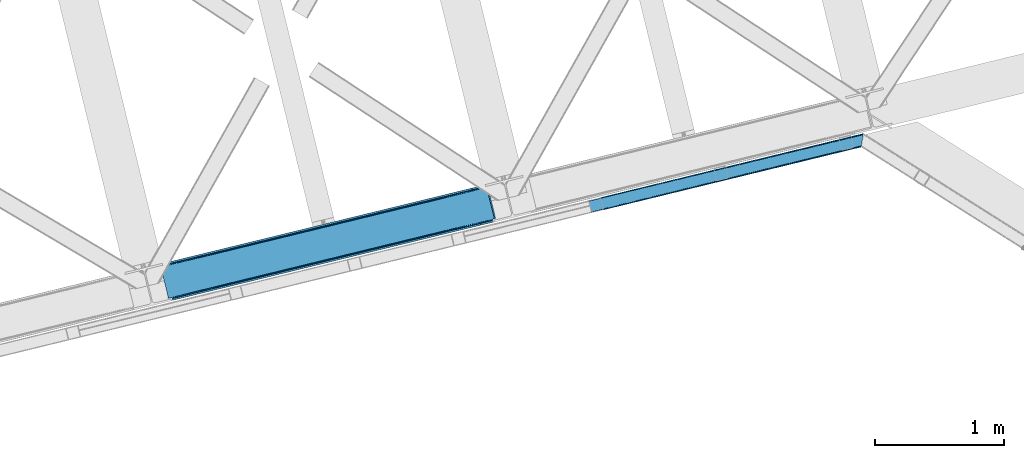
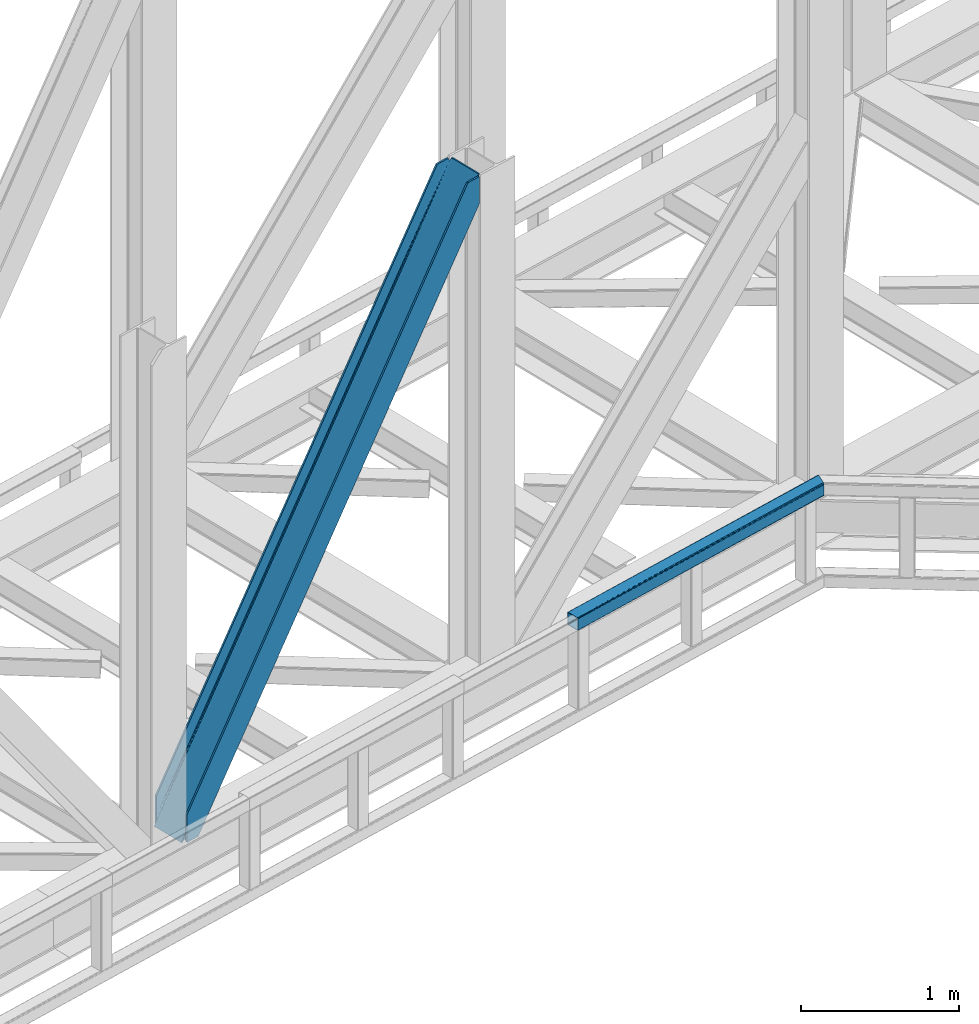
# One storey, part 71 of 92: 1 beam, 1 member.
"""IFC4 building model written with IfcOpenShell, lengths in millimetres."""

from ifc_helpers import new_model, entity, si_unit, converted_unit, derived_unit, direction, frame, origin, place, context, subcontext, project, spatial, triangles, type_object, element, save


model = new_model("IFC4")

# Units and contexts
model_context = context("Model", 3, precision=0.01, world=origin(), true_north=direction((6.12303176911189e-17, 1.0)))
plan_context = context("Plan", 3, precision=0.01, world=origin(), true_north=direction((6.12303176911189e-17, 1.0)))
body_context = subcontext(model_context, "Body", "Model", "MODEL_VIEW")
ifc_project = project(units=[si_unit("LENGTHUNIT", "METRE", prefix="MILLI"), si_unit("AREAUNIT", "SQUARE_METRE"), si_unit("VOLUMEUNIT", "CUBIC_METRE"), converted_unit("PLANEANGLEUNIT", "DEGREE", entity("IfcRatioMeasure", 0.0174532925199433), si_unit("PLANEANGLEUNIT", "RADIAN"), dimensions=[0, 0, 0, 0, 0, 0, 0]), si_unit("MASSUNIT", "GRAM", prefix="KILO"), derived_unit("MASSDENSITYUNIT", [(si_unit("MASSUNIT", "GRAM", prefix="KILO"), 1), (si_unit("LENGTHUNIT", "METRE"), -3)]), derived_unit("MOMENTOFINERTIAUNIT", [(si_unit("LENGTHUNIT", "METRE"), 4)]), si_unit("TIMEUNIT", "SECOND"), si_unit("FREQUENCYUNIT", "HERTZ"), si_unit("THERMODYNAMICTEMPERATUREUNIT", "DEGREE_CELSIUS"), derived_unit("THERMALTRANSMITTANCEUNIT", [(si_unit("MASSUNIT", "GRAM", prefix="KILO"), 1), (si_unit("THERMODYNAMICTEMPERATUREUNIT", "KELVIN"), -1), (si_unit("TIMEUNIT", "SECOND"), -3)]), derived_unit("VOLUMETRICFLOWRATEUNIT", [(si_unit("LENGTHUNIT", "METRE"), 3), (si_unit("TIMEUNIT", "SECOND"), -1)]), derived_unit("MASSFLOWRATEUNIT", [(si_unit("MASSUNIT", "GRAM", prefix="KILO"), 1), (si_unit("TIMEUNIT", "SECOND"), -1)]), derived_unit("ROTATIONALFREQUENCYUNIT", [(si_unit("TIMEUNIT", "SECOND"), -1)]), si_unit("ELECTRICCURRENTUNIT", "AMPERE"), si_unit("ELECTRICVOLTAGEUNIT", "VOLT"), si_unit("POWERUNIT", "WATT"), si_unit("FORCEUNIT", "NEWTON", prefix="KILO"), si_unit("ILLUMINANCEUNIT", "LUX"), si_unit("LUMINOUSFLUXUNIT", "LUMEN"), si_unit("LUMINOUSINTENSITYUNIT", "CANDELA"), derived_unit("USERDEFINED", [(si_unit("MASSUNIT", "GRAM", prefix="KILO"), -1), (si_unit("LENGTHUNIT", "METRE"), -2), (si_unit("TIMEUNIT", "SECOND"), 3), (si_unit("LUMINOUSFLUXUNIT", "LUMEN"), 1)]), derived_unit("LINEARVELOCITYUNIT", [(si_unit("LENGTHUNIT", "METRE"), 1), (si_unit("TIMEUNIT", "SECOND"), -1)]), si_unit("PRESSUREUNIT", "PASCAL"), derived_unit("USERDEFINED", [(si_unit("LENGTHUNIT", "METRE"), -2), (si_unit("MASSUNIT", "GRAM", prefix="KILO"), 1), (si_unit("TIMEUNIT", "SECOND"), -2)]), derived_unit("LINEARFORCEUNIT", [(si_unit("MASSUNIT", "GRAM", prefix="KILO"), 1), (si_unit("LENGTHUNIT", "METRE"), 1), (si_unit("TIMEUNIT", "SECOND"), -2), (si_unit("LENGTHUNIT", "METRE"), -1)]), derived_unit("PLANARFORCEUNIT", [(si_unit("MASSUNIT", "GRAM", prefix="KILO"), 1), (si_unit("LENGTHUNIT", "METRE"), 1), (si_unit("TIMEUNIT", "SECOND"), -2), (si_unit("LENGTHUNIT", "METRE"), -2)])], contexts=[model_context, plan_context])

# Site, building, storey
site_placement = place(None, origin())
site = spatial("IfcSite", under=ifc_project, at=site_placement, CompositionType="ELEMENT")
building_placement = place(site_placement, origin())
building = spatial("IfcBuilding", under=site, at=building_placement, CompositionType="ELEMENT")
storey_placement = place(building_placement, frame((0.0, 0.0, 15900.0)))
storey = spatial("IfcBuildingStorey", under=building, at=storey_placement, Name="05", CompositionType="ELEMENT", Elevation=15900.0)

# Member
member_type = type_object("IfcMemberType", PredefinedType="BRACE")
member_placement = place(storey_placement, frame((-10911.6, 14812.79, 3695.0)))
element("IfcMember", 1, at=member_placement, inside=storey, type_object=member_type, ObjectType="Steel Vertical Brace", PredefinedType="BRACE", context=body_context, shape_type="Tessellation", body=[
    triangles([(2543.71740875244, 876.026760864259, 3910.2403930664), (2543.86042327881, 877.205758666993, 3909.96134033203), (2542.34249267578, 876.83485107422, 3911.00081176758), (2544.23714447021, 869.063232421875, 3911.00081176758), (2527.1870223999, 873.140890502929, 3906.29412231445), (2530.23276672363, 873.883868408204, 3911.00081176758), (2527.1870223999, 873.140890502929, 3884.1908203125), (2518.86892547607, 874.429183959961, 3898.31321411133), (2521.01472473145, 873.423431396484, 3899.16199951172), (2522.8994934082, 872.957180786134, 3877.06799926758), (2518.86892547607, 874.429183959961, 3868.81036376953), (2517.28762664795, 875.594229125976, 3898.850390625), (2517.28762664795, 875.594229125976, 3864.49202270508), (2515.87201538086, 877.455743408203, 3857.29478759765), (2515.70574645996, 877.331332397462, 3901.61533813476), (2513.8953918457, 881.222955322266, 3911.00081176758), (2514.70987701416, 878.98239440918, 3851.39514770508), (2514.17793273926, 880.262548828125, 3838.64708862305), (2514.70987701416, 878.98239440918, 3906.82664794922), (2514.37326965332, 879.734674072266, 3911.00081176758), (2514.17793273926, 880.262548828125, 3698.36960449219), (2513.8953918457, 881.222955322266, 3698.30216674805), (2522.8994934082, 872.957180786134, 3900.77120361328), (1281.82757263184, 579.864605712892, 1933.79126586914), (121.508862304687, 297.023730468751, 0.0), (1706.0627243042, 683.275735473633, 2589.5349609375), (2130.29787597656, 786.688027954102, 3245.28098144531), (857.588351440429, 476.451150512696, 1278.04757080078), (30.7527740478508, 274.901824951172, 0.0), (433.352618408202, 373.040020751954, 622.301550292967), (2511.05370483398, 892.881546020508, 3698.30216674805), (118.429980468749, 309.6543548584, 0.0), (2511.05370483398, 892.881546020508, 3911.00081176758), (2415.21013641357, 869.519018554687, 3911.00081176758), (23.8834259033192, 286.608087158203, 214.700848388671), (23.8834259033192, 286.608087158203, 0.0), (26.9576568603516, 273.658877563477, 0.0), (26.7251129150391, 274.949496459962, 0.0), (26.7251129150391, 274.949496459962, 214.700848388671), (2509.04452514648, 879.011462402344, 3911.00081176758), (2418.28901824951, 856.88839416504, 3911.00081176758), (26.9169616699219, 273.966998291016, 214.633410644528), (1250.04869842529, 572.117404174805, 1964.95680541992), (1676.92729339599, 676.173843383789, 2624.78862304687), (2103.80530700683, 780.230282592775, 3284.61811523437), (823.166033935546, 468.06096496582, 1305.12731323242), (26.9169616699219, 273.966998291016, 74.3536010742173), (396.287438964842, 364.004525756836, 645.295495605467), (25.4356567382802, 266.62907409668, 14.6874755859353), (23.9973724365227, 264.751281738281, 13.8410156249993), (22.5346710205067, 263.467639160157, 35.9326904296868), (25.4356567382802, 266.62907409668, 44.192651367186), (26.2995574951165, 268.389431762696, 14.1502990722656), (26.0007385253903, 268.182467651368, 48.2249633789033), (26.9088226318345, 270.661386108399, 54.6571289062485), (26.9088226318345, 270.661386108399, 11.3853515624978), (27.0332336425781, 272.584524536132, 61.6055419921868), (27.0332336425781, 272.584524536132, 6.17404174804688), (22.5346710205067, 263.467639160157, 12.2294860839829), (18.6395599365223, 261.656121826172, 28.8121948242188), (18.6395599365223, 261.656121826172, 6.70889282226563), (0.0, 257.112213134766, 0.0), (14.3014526367188, 260.598046875, 0.0), (412.365527343749, 356.486380004882, 636.079779052732), (0.597637939452397, 256.057626342774, 0.0), (4.0857971191399, 249.874282836914, 0.0), (2122.62276306152, 766.290435791016, 3274.64197998047), (2534.31856384277, 866.644775390625, 3911.00081176758), (2530.82982330322, 872.828118896485, 3911.00081176758), (2119.88455810547, 772.712136840821, 3275.40239868164), (2109.70145874023, 780.257025146484, 3280.80206909179), (2115.34762573242, 777.617651367187, 3277.56505737305), (407.828594970702, 361.391894531251, 638.242437744138), (402.183590698241, 364.031268310548, 641.479449462888), (415.109545898436, 350.065841674805, 635.319360351561), (829.062185668945, 468.087707519531, 1301.30894165039), (1255.94019927978, 572.144146728517, 1961.14075927734), (1682.81821289062, 676.199423217773, 2620.97025146484), (834.707189941406, 465.447171020509, 1298.07192993164), (1261.58578491211, 569.503610229493, 1957.90374755859), (1688.46903076172, 673.561212158203, 2617.73323974609), (839.248773193358, 460.543981933593, 1295.90927124023), (1266.12736816406, 564.600421142579, 1955.74108886719), (1693.00596313476, 668.656860351563, 2615.57058105469), (841.986978149413, 454.121118164063, 1295.15117797851), (1268.86557312012, 558.177557373047, 1954.98067016601), (1695.74416809082, 662.233996582032, 2614.81248779297), (428.111077880858, 370.35181274414, 626.119921874997), (424.312472534179, 365.409091186524, 629.35693359375), (2119.48225708008, 772.61446838379, 3254.49669799805), (2121.25307922363, 779.057098388672, 3252.33403930664), (423.061386108398, 352.004095458984, 632.280010986327), (14.0084472656235, 252.292739868164, 0.0), (14.2607574462891, 259.388818359375, 0.0), (422.536999511718, 358.966461181641, 631.519592285156), (2125.05110321045, 783.998657226563, 3249.09702758789), (846.772732543945, 462.377590942384, 1287.26328735351), (847.297119140625, 455.415225219727, 1288.02370605469), (1271.00730285644, 565.789883422853, 1943.00930786133), (1271.53168945312, 558.827517700196, 1943.76740112304), (1695.24245452881, 669.201013183594, 2598.75300292969), (1695.76684112549, 662.239810180665, 2599.5110961914), (2120.00199279785, 765.650939941406, 3255.25711669922), (848.548205566405, 468.821383666993, 1285.10062866211), (1272.78277587891, 572.233676147462, 1940.84664916992), (1697.01792755127, 675.644805908203, 2596.59034423828), (852.345648193359, 473.762942504884, 1281.86361694336), (1276.58079986572, 577.175234985352, 1937.60963745117), (1700.81595153808, 680.586364746094, 2593.35333251953), (2589.49949798584, 640.273709106446, 3911.00081176758), (2177.80311584473, 539.91820678711, 3274.64197998047), (1324.04650726318, 331.806491088868, 1954.98067016601), (1750.92452087402, 435.861767578126, 2614.81248779297), (897.167330932616, 227.750051879882, 1295.15117797851), (470.28989868164, 123.693612670899, 635.319360351561), (59.2661499023434, 23.5020538330082, 0.0), (2599.41749725342, 642.691003417969, 3911.00081176758), (2175.18234558105, 539.279873657228, 3255.25711669922), (1750.94719390869, 435.867581176759, 2599.5110961914), (1326.71204223633, 332.456451416016, 1943.76740112304), (902.477471923827, 229.044158935547, 1288.02370605469), (478.2417388916, 125.631866455078, 632.280010986327), (69.1899627685543, 25.9216735839855, 0.0), (59.0138397216797, 16.4071380615242, 0.0), (72.6781219482418, 19.7383300781257, 0.0), (58.9696563720699, 15.1955841064464, 0.0), (73.2711090087887, 18.6825805664066, 0.0), (77.6092163085923, 19.7394927978512, 6.70889282226563), (77.6092163085923, 19.7394927978512, 28.8121948242188), (2589.24718780517, 633.178793334961, 3911.00081176758), (2601.31214904785, 634.919384765626, 3911.00081176758), (2589.2024230957, 631.967239379883, 3911.00081176758), (2602.83007965088, 635.289129638672, 3909.96134033203), (2602.16035308838, 636.270465087891, 3910.2403930664), (2586.15667877197, 631.22426147461, 3906.29412231445), (2586.15667877197, 631.22426147461, 3884.1908203125), (2572.75052032471, 617.663461303711, 3911.00081176758), (2577.81474609375, 619.473815917969, 3911.00081176758), (2577.76707458496, 620.297021484375, 3906.82664794922), (2172.75865631103, 521.571652221681, 3280.80206909179), (2577.89206695557, 622.220159912109, 3901.61533813476), (2578.49668121338, 624.490951538086, 3898.850390625), (2582.26563720703, 629.413906860353, 3900.77120361328), (2178.32750244141, 532.955841064453, 3275.40239868164), (2580.80293579101, 628.130264282227, 3899.15967407226), (2579.36465148926, 626.252471923828, 3898.31321411133), (2176.55668029785, 526.514373779297, 3277.56505737305), (470.809634399413, 116.730084228517, 636.079779052732), (469.038812255858, 110.28861694336, 638.242437744138), (81.9008148193352, 19.9243652343757, 35.9326904296868), (85.931964111327, 18.4523620605469, 44.192651367186), (87.5086120605465, 17.2861541748043, 48.5109924316384), (2167.51188354492, 518.882281494141, 3284.61811523437), (459.994015502929, 102.656524658203, 645.295495605467), (465.240206909179, 105.345895385743, 641.479449462888), (90.6223754882813, 12.6189971923832, 74.3536010742173), (90.0910125732407, 13.8991516113292, 61.6055419921868), (88.9282928466782, 15.4258026123043, 55.7059020996094), (897.691717529297, 220.787686157228, 1295.90927124023), (1324.57089385986, 324.844125366211, 1955.74108886719), (1751.4489074707, 428.900564575195, 2615.57058105469), (895.916244506836, 214.343893432617, 1298.07192993164), (1322.79483947754, 318.400332641602, 1957.90374755859), (1749.67808532715, 422.457934570313, 2617.73323974609), (892.118801879882, 209.402334594726, 1301.30894165039), (1318.99739685059, 313.458773803712, 1961.14075927734), (1745.87599182129, 417.515213012695, 2620.97025146484), (886.871447753905, 206.712963867189, 1305.12731323242), (1313.75469360351, 310.7705657959, 1964.95680541992), (1740.63328857422, 414.827005004883, 2624.78862304687), (90.6223754882813, 12.6189971923832, 214.633410644528), (2481.99501342773, 595.541555786132, 3911.00081176758), (491.167694091797, 111.666439819337, 626.119921874997), (89.094561767577, 15.550213623048, 11.3853515624978), (87.5086120605465, 17.2861541748043, 14.1502990722656), (90.0910125732407, 13.8991516113292, 6.17404174804688), (480.981106567382, 119.210165405273, 631.519592285156), (83.7855834960938, 19.4581146240234, 13.8386901855447), (81.9008148193352, 19.9243652343757, 12.2294860839829), (85.931964111327, 18.4523620605469, 14.6874755859353), (485.521527099609, 114.305813598634, 629.35693359375), (2182.46213378906, 527.953820800782, 3252.33403930664), (2582.26563720703, 629.413906860353, 3877.06799926758), (2579.36465148926, 626.252471923828, 3868.81036376953), (2177.92520141602, 532.858172607423, 3254.49669799805), (2578.79608154297, 624.697915649414, 3864.77572631836), (2577.89206695557, 622.220159912109, 3858.34588623047), (2188.10830078125, 525.313284301757, 3249.09702758789), (2577.76707458496, 620.297021484375, 3851.39514770508), (94.4593505859375, 13.5538238525387, 0.0), (90.5188934326161, 12.9108398437511, 0.0), (497.059194946289, 111.692019653321, 622.301550292967), (2577.88392791748, 618.915710449219, 3838.64708862305), (2194.00387115478, 525.340026855469, 3245.28098144531), (915.403427124023, 215.077569580078, 1281.86361694336), (921.294927978515, 215.10431213379, 1278.04757080078), (1339.63799743652, 318.489862060547, 1937.60963745117), (1345.53414916992, 318.516604614259, 1933.79126586914), (1763.87314910889, 421.902154541016, 2593.35333251953), (1769.76930084228, 421.928897094727, 2589.5349609375), (909.757260131835, 217.718106079103, 1285.10062866211), (1333.9924118042, 321.129235839844, 1940.84664916992), (1758.2269821167, 424.541528320313, 2596.59034423828), (905.215676879881, 222.621295166016, 1287.26328735351), (1329.45082855225, 326.033587646485, 1943.00930786133), (1753.68598022461, 429.444717407227, 2598.75300292969), (90.9049163818345, 11.6585906982418, 0.0), (90.9049163818345, 11.6585906982418, 214.700848388671), (2485.07389526367, 582.910931396485, 3911.00081176758), (93.7466033935543, 0.0, 214.700848388671), (93.7466033935543, 0.0, 0.0), (188.293157958984, 23.046267700196, 0.0), (185.214276123046, 35.6768920898448, 0.0), (2577.88392791748, 618.915710449219, 3698.36960449219), (2578.07577667236, 617.932049560548, 3911.00081176758), (2578.07577667236, 617.932049560548, 3698.30216674805), (2580.91746368408, 606.273458862304, 3698.30216674805), (2580.91746368408, 606.273458862304, 3911.00081176758)], [[1, 2, 3], [3, 4, 1], [3, 5, 6], [5, 3, 2], [7, 5, 2], [8, 9, 10], [10, 11, 8], [8, 11, 12], [13, 12, 11], [14, 15, 12], [16, 17, 18], [19, 15, 14], [16, 20, 19], [19, 17, 16], [14, 17, 19], [18, 21, 22], [22, 16, 18], [13, 14, 12], [9, 23, 10], [5, 7, 23], [10, 23, 7], [21, 24, 25], [26, 21, 27], [21, 26, 24], [21, 18, 27], [28, 25, 24], [29, 25, 30], [28, 30, 25], [31, 22, 32], [22, 21, 25], [25, 32, 22], [16, 22, 33], [31, 33, 22], [34, 31, 35], [31, 34, 33], [32, 35, 31], [36, 35, 32], [32, 29, 36], [29, 32, 25], [37, 38, 29], [38, 36, 29], [38, 39, 35], [35, 36, 38], [16, 33, 40], [20, 16, 40], [34, 40, 33], [34, 41, 40], [39, 34, 35], [41, 39, 42], [39, 41, 34], [41, 42, 43], [43, 44, 41], [44, 45, 41], [40, 41, 45], [46, 43, 42], [42, 47, 48], [48, 46, 42], [49, 50, 51], [51, 52, 49], [53, 49, 52], [52, 54, 53], [55, 56, 53], [57, 58, 55], [56, 55, 58], [38, 37, 58], [58, 47, 38], [39, 38, 47], [47, 42, 39], [57, 47, 58], [54, 55, 53], [50, 59, 51], [51, 59, 60], [61, 60, 59], [60, 61, 62], [63, 62, 61], [64, 65, 66], [67, 68, 69], [70, 8, 12], [70, 69, 23], [23, 9, 70], [9, 8, 70], [69, 5, 23], [69, 6, 5], [71, 72, 12], [12, 15, 71], [19, 40, 45], [45, 71, 19], [73, 74, 57], [57, 55, 73], [64, 51, 60], [60, 65, 64], [60, 62, 65], [64, 73, 54], [54, 52, 64], [52, 51, 64], [55, 54, 73], [74, 48, 47], [47, 57, 74], [19, 20, 40], [15, 19, 71], [12, 72, 70], [69, 70, 67], [66, 75, 64], [76, 46, 48], [48, 74, 76], [77, 43, 46], [46, 76, 77], [78, 44, 43], [43, 77, 78], [71, 45, 78], [44, 78, 45], [79, 76, 73], [74, 73, 76], [80, 77, 79], [76, 79, 77], [81, 78, 80], [77, 80, 78], [72, 71, 78], [78, 81, 72], [82, 79, 64], [73, 64, 79], [83, 80, 79], [79, 82, 83], [84, 81, 80], [80, 83, 84], [70, 72, 81], [81, 84, 70], [85, 82, 64], [64, 75, 85], [86, 83, 82], [82, 85, 86], [87, 84, 86], [83, 86, 84], [67, 70, 87], [84, 87, 70], [88, 89, 53], [53, 56, 88], [30, 88, 58], [58, 29, 30], [90, 10, 7], [7, 1, 90], [7, 2, 1], [90, 91, 13], [13, 11, 90], [11, 10, 90], [92, 93, 94], [95, 49, 53], [95, 94, 61], [61, 59, 95], [59, 50, 95], [50, 49, 95], [94, 63, 61], [53, 89, 95], [94, 95, 92], [14, 91, 17], [14, 13, 91], [91, 96, 17], [18, 17, 96], [96, 27, 18], [58, 37, 29], [56, 58, 88], [97, 98, 92], [92, 95, 97], [99, 100, 98], [98, 97, 99], [101, 102, 100], [100, 99, 101], [90, 103, 102], [102, 101, 90], [1, 4, 90], [103, 90, 4], [104, 97, 95], [95, 89, 104], [105, 99, 104], [97, 104, 99], [106, 101, 105], [99, 105, 101], [91, 90, 101], [101, 106, 91], [107, 104, 88], [89, 88, 104], [108, 105, 107], [104, 107, 105], [109, 106, 105], [105, 108, 109], [96, 91, 106], [106, 109, 96], [28, 107, 88], [88, 30, 28], [24, 108, 107], [107, 28, 24], [26, 109, 24], [108, 24, 109], [27, 96, 26], [109, 26, 96], [110, 68, 67], [87, 111, 67], [112, 113, 87], [112, 87, 86], [67, 111, 110], [87, 113, 111], [85, 114, 112], [112, 86, 85], [85, 75, 115], [66, 116, 75], [85, 115, 114], [75, 116, 115], [4, 117, 118], [119, 103, 118], [100, 102, 119], [100, 119, 120], [118, 103, 4], [119, 102, 103], [98, 100, 120], [120, 121, 98], [121, 122, 92], [123, 93, 122], [121, 92, 98], [122, 93, 92], [66, 116, 93], [116, 124, 125], [124, 126, 125], [62, 65, 63], [65, 66, 94], [93, 116, 123], [127, 125, 126], [125, 123, 116], [93, 94, 66], [94, 63, 65], [128, 129, 126], [126, 127, 128], [110, 130, 131], [130, 132, 131], [6, 69, 3], [3, 69, 68], [110, 117, 68], [68, 117, 4], [110, 131, 117], [4, 3, 68], [133, 134, 131], [117, 131, 134], [131, 135, 133], [131, 132, 135], [135, 136, 133], [137, 138, 139], [140, 141, 142], [140, 139, 141], [130, 143, 135], [144, 145, 143], [144, 146, 145], [143, 130, 144], [135, 132, 130], [144, 147, 142], [142, 146, 144], [111, 144, 130], [148, 115, 116], [149, 150, 151], [148, 124, 129], [129, 149, 148], [129, 150, 149], [124, 126, 129], [151, 152, 149], [116, 124, 148], [130, 110, 111], [142, 147, 140], [137, 139, 153], [140, 153, 139], [154, 155, 156], [157, 156, 155], [157, 149, 158], [157, 155, 149], [152, 158, 149], [159, 114, 148], [115, 148, 114], [160, 112, 159], [114, 159, 112], [161, 113, 112], [112, 160, 161], [144, 111, 113], [113, 161, 144], [162, 159, 148], [148, 149, 162], [163, 160, 162], [159, 162, 160], [164, 161, 163], [160, 163, 161], [147, 144, 164], [161, 164, 144], [165, 162, 149], [149, 155, 165], [166, 163, 162], [162, 165, 166], [167, 164, 163], [163, 166, 167], [140, 147, 167], [164, 167, 147], [168, 165, 154], [155, 154, 165], [169, 166, 168], [165, 168, 166], [170, 167, 169], [166, 169, 167], [153, 140, 167], [167, 170, 153], [169, 171, 172], [172, 153, 170], [153, 172, 137], [170, 169, 172], [171, 169, 168], [168, 154, 171], [156, 171, 154], [173, 174, 175], [173, 176, 174], [177, 178, 179], [177, 180, 178], [179, 128, 177], [128, 125, 177], [128, 127, 125], [177, 181, 175], [175, 180, 177], [122, 177, 125], [182, 183, 184], [185, 134, 136], [136, 182, 185], [136, 183, 182], [134, 133, 136], [184, 186, 182], [182, 186, 187], [187, 188, 182], [187, 189, 188], [190, 191, 176], [173, 192, 176], [190, 176, 192], [189, 193, 188], [194, 188, 193], [125, 123, 122], [175, 181, 173], [195, 196, 173], [192, 173, 196], [197, 198, 195], [196, 195, 198], [199, 200, 198], [198, 197, 199], [188, 194, 200], [200, 199, 188], [201, 195, 173], [173, 181, 201], [202, 197, 195], [195, 201, 202], [203, 199, 197], [197, 202, 203], [182, 188, 199], [199, 203, 182], [204, 201, 177], [181, 177, 201], [205, 202, 201], [201, 204, 205], [206, 203, 205], [202, 205, 203], [185, 182, 206], [203, 206, 182], [121, 204, 122], [177, 122, 204], [120, 205, 121], [204, 121, 205], [119, 206, 205], [205, 120, 119], [118, 185, 206], [206, 119, 118], [117, 134, 185], [185, 118, 117], [180, 151, 150], [150, 179, 178], [175, 158, 152], [175, 152, 151], [151, 180, 175], [207, 157, 176], [176, 157, 158], [158, 174, 176], [207, 208, 156], [171, 156, 208], [156, 157, 207], [176, 191, 207], [175, 174, 158], [150, 178, 180], [179, 150, 129], [129, 128, 179], [208, 172, 171], [209, 208, 210], [208, 209, 172], [211, 210, 207], [208, 207, 210], [212, 190, 211], [190, 212, 213], [191, 207, 190], [207, 211, 190], [198, 214, 213], [194, 214, 200], [194, 193, 214], [198, 200, 214], [213, 196, 198], [192, 196, 213], [213, 190, 192], [146, 184, 183], [183, 143, 145], [142, 186, 184], [142, 187, 186], [184, 146, 142], [215, 189, 139], [187, 141, 139], [139, 189, 187], [214, 193, 216], [215, 216, 193], [193, 189, 215], [139, 138, 215], [142, 141, 187], [183, 145, 146], [136, 135, 143], [143, 183, 136], [217, 209, 210], [217, 218, 209], [210, 212, 217], [211, 212, 210], [215, 138, 137], [218, 215, 137], [137, 209, 218], [209, 137, 172], [214, 216, 213], [216, 217, 212], [212, 213, 216], [218, 217, 216], [216, 215, 218]]),
])

# Beam
beam_type = type_object("IfcBeamType", PredefinedType="BEAM")
beam_placement = place(storey_placement, frame((-7589.58, 15490.73, 3780.0)))
element("IfcBeam", 2, at=beam_placement, inside=storey, type_object=beam_type, ObjectType="Steel Beam", PredefinedType="BEAM", context=body_context, shape_type="Tessellation", body=[
    triangles([(2118.81718139648, 521.003082275391, 99.9985473632842), (2132.86109161377, 606.769940185546, 99.9985473632842), (2.36846008300745, 87.4388488769528, 99.9985473632842), (21.3143966674797, 9.71452331542969, 99.9985473632842), (1.46212005615234, 91.1572265625, 99.2381286621094), (0.693562316893804, 94.3093597412098, 97.0708190917976), (2133.48314666748, 610.56040649414, 98.5335205078154), (0.180221557617188, 96.4150451660153, 93.8268310546882), (2134.10520172119, 614.350872802734, 97.0708190917976), (0.0, 97.1545349121079, 89.9991577148467), (2134.35983734131, 615.920544433593, 93.5338256835967), (2134.61796112061, 617.490216064452, 89.9991577148467), (2134.61796112061, 617.490216064452, 9.9993896484375), (0.0, 97.1545349121079, 9.9993896484375), (2134.35983734131, 615.920544433593, 6.46239624023656), (0.180221557617188, 96.4150451660153, 6.17171630859593), (2134.10520172119, 614.350872802734, 2.92772827148656), (0.693562316893804, 94.3093597412098, 2.92772827148656), (2133.48314666748, 610.56040649414, 1.46270141601781), (1.46212005615234, 91.1572265625, 0.760418701174785), (2132.86109161377, 606.769940185546, 0.0), (2.36846008300745, 87.4388488769528, 0.0), (2118.81718139648, 521.003082275391, 0.0), (21.3143966674797, 9.71452331542969, 0.0), (2118.19512634277, 517.212615966797, 1.46270141601781), (22.2207366943358, 5.99730834960792, 0.760418701174785), (2117.57714080811, 513.423312377929, 2.92772827148656), (22.9892944335934, 2.84517517089807, 2.92772827148656), (2117.31843566895, 511.852478027344, 6.46239624023656), (23.5026351928709, 0.739489746092659, 6.17171630859593), (2117.05973052979, 510.282806396484, 9.9993896484375), (23.6828567504881, 0.0, 9.9993896484375), (2117.05973052979, 510.282806396484, 89.9991577148467), (23.6828567504881, 0.0, 89.9991577148467), (23.5026351928709, 0.739489746092659, 93.8268310546882), (22.9892944335934, 2.84517517089807, 97.0708190917976), (2117.31843566895, 511.852478027344, 93.5338256835967), (22.2207366943358, 5.99730834960792, 99.2381286621094), (2117.57714080811, 513.423312377929, 97.0708190917976), (2118.19512634277, 517.212615966797, 98.5335205078154), (1.87779235839844, 89.4515167236314, 7.92742309570531), (1.36445159912091, 91.5572021484368, 11.1714111328147), (1.18423004150372, 92.2966918945313, 14.9990844726563), (3.55269012451117, 82.5810058593743, 4.99969482421875), (2.64635009765607, 86.2993835449215, 5.76011352539354), (1.87779235839844, 89.4515167236314, 92.0711242675789), (1.18423004150372, 92.2966918945313, 84.9994628906279), (1.36445159912091, 91.5572021484368, 88.8248107910185), (3.55269012451117, 82.5810058593743, 94.9988525390654), (2.64635009765607, 86.2993835449215, 94.2384338378906), (21.8050643920897, 7.70301818847656, 7.92742309570531), (20.130166625976, 14.5723663330064, 4.99969482421875), (21.036506652832, 10.8551513671864, 5.76011352539354), (22.4986267089844, 4.85784301757667, 14.9990844726563), (22.3184051513672, 5.59733276367115, 11.1714111328147), (21.8050643920897, 7.70301818847656, 92.0711242675789), (20.130166625976, 14.5723663330064, 94.9988525390654), (21.036506652832, 10.8551513671864, 94.2384338378906), (22.4986267089844, 4.85784301757667, 84.9994628906279), (22.3184051513672, 5.59733276367115, 88.8248107910185), (2133.22444152832, 608.989572143553, 92.0711242675789), (2133.48314666748, 610.56040649414, 88.5341308593779), (2133.74185180664, 612.130078124999, 84.9994628906279), (2133.74185180664, 612.130078124999, 14.9990844726563), (2131.9849822998, 601.409802246093, 94.9988525390654), (2119.69329071045, 526.363220214844, 94.9988525390654), (2132.60703735352, 605.200268554687, 93.5338256835967), (2133.22444152832, 608.989572143553, 7.92742309570531), (2133.48314666748, 610.56040649414, 11.4644165039063), (2132.60703735352, 605.200268554687, 6.46239624023656), (2131.9849822998, 601.409802246093, 4.99969482421875), (2118.45325012207, 518.783450317382, 92.0711242675789), (2118.19512634277, 517.212615966797, 88.5341308593779), (2119.07588653564, 522.573916625975, 93.5338256835967), (2117.94049072266, 515.642944335938, 84.9994628906279), (2118.45325012207, 518.783450317382, 7.92742309570531), (2119.69329071045, 526.363220214844, 4.99969482421875), (2119.07588653564, 522.573916625975, 6.46239624023656), (2117.94049072266, 515.642944335938, 14.9990844726563), (2118.19512634277, 517.212615966797, 11.4644165039063)], [[1, 2, 3], [3, 4, 1], [5, 3, 2], [6, 5, 7], [8, 6, 9], [10, 8, 11], [11, 12, 10], [9, 11, 8], [7, 9, 6], [2, 7, 5], [13, 14, 12], [10, 12, 14], [14, 13, 15], [16, 15, 17], [18, 17, 19], [20, 19, 21], [21, 22, 20], [19, 20, 18], [17, 18, 16], [15, 16, 14], [21, 23, 22], [24, 22, 23], [24, 23, 25], [26, 25, 27], [28, 27, 29], [30, 29, 31], [31, 32, 30], [29, 30, 28], [27, 28, 26], [25, 26, 24], [32, 31, 33], [33, 34, 32], [35, 34, 33], [36, 35, 37], [38, 36, 39], [4, 38, 40], [40, 1, 4], [39, 40, 38], [37, 39, 36], [33, 37, 35], [16, 41, 42], [43, 10, 14], [16, 42, 14], [16, 18, 41], [42, 43, 14], [41, 18, 20], [44, 22, 24], [22, 45, 20], [45, 22, 44], [45, 41, 20], [8, 46, 6], [47, 10, 43], [10, 48, 8], [48, 10, 47], [8, 48, 46], [3, 49, 4], [5, 6, 46], [46, 50, 5], [50, 49, 3], [3, 5, 50], [51, 26, 28], [24, 52, 44], [24, 53, 52], [53, 24, 26], [51, 53, 26], [54, 32, 34], [30, 55, 51], [28, 30, 51], [55, 30, 32], [54, 55, 32], [38, 56, 36], [4, 49, 57], [57, 58, 4], [58, 56, 38], [38, 4, 58], [35, 36, 56], [34, 59, 54], [60, 34, 35], [34, 60, 59], [60, 35, 56], [11, 61, 62], [63, 64, 12], [12, 11, 62], [9, 61, 11], [62, 63, 12], [61, 9, 7], [65, 2, 66], [2, 67, 7], [67, 2, 65], [67, 61, 7], [68, 19, 17], [64, 13, 12], [69, 15, 13], [69, 13, 64], [17, 15, 68], [19, 70, 21], [15, 69, 68], [19, 68, 70], [21, 71, 23], [71, 21, 70], [72, 37, 73], [1, 66, 2], [1, 40, 74], [1, 74, 66], [74, 40, 72], [73, 33, 75], [37, 72, 39], [39, 72, 40], [75, 33, 31], [37, 33, 73], [25, 76, 27], [23, 71, 77], [78, 23, 77], [25, 78, 76], [25, 23, 78], [29, 27, 76], [31, 79, 75], [80, 31, 29], [31, 80, 79], [80, 29, 76], [65, 66, 49], [57, 49, 66], [47, 63, 62], [48, 62, 61], [46, 61, 67], [50, 67, 65], [65, 49, 50], [67, 50, 46], [61, 46, 48], [62, 48, 47], [43, 64, 63], [63, 47, 43], [45, 44, 71], [41, 45, 70], [42, 41, 68], [43, 42, 69], [69, 64, 43], [68, 69, 42], [70, 68, 41], [71, 70, 45], [77, 71, 44], [44, 52, 77], [55, 54, 79], [51, 55, 80], [53, 51, 76], [52, 53, 78], [78, 77, 52], [76, 78, 53], [80, 76, 51], [79, 80, 55], [79, 54, 75], [59, 75, 54], [57, 66, 74], [58, 74, 72], [56, 72, 73], [60, 73, 75], [75, 59, 60], [73, 60, 56], [72, 56, 58], [74, 58, 57]]),
])

save(model, "model.ifc")
